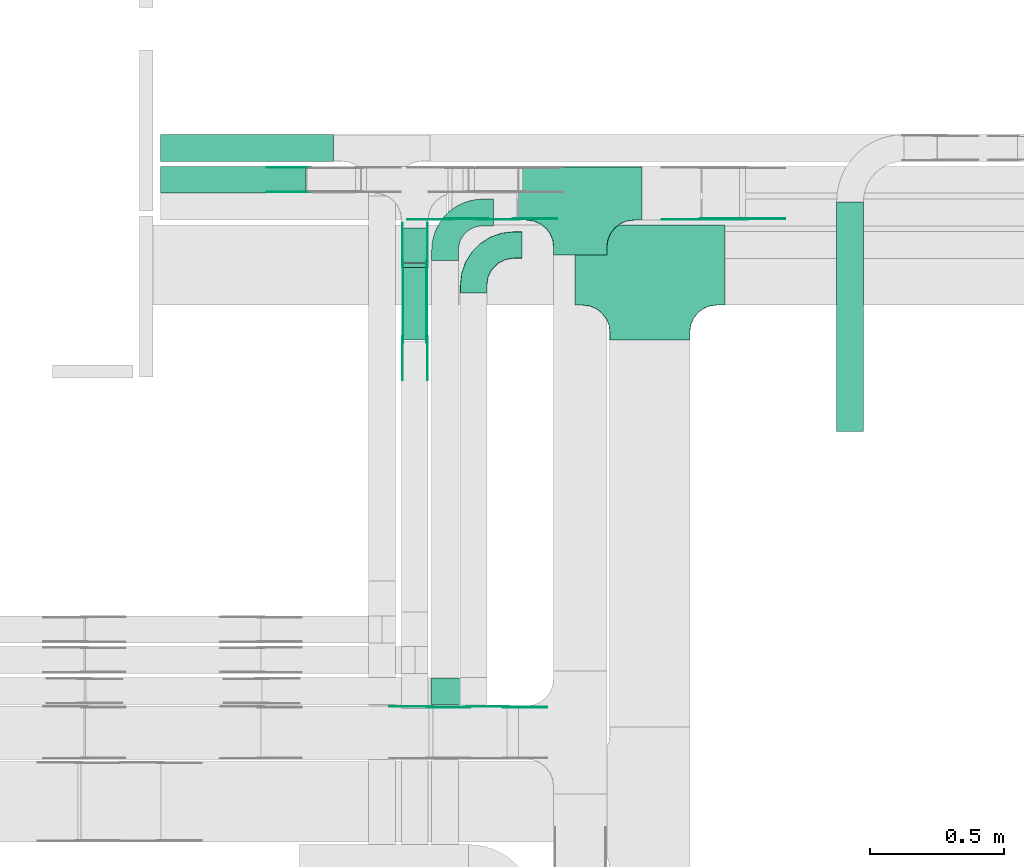
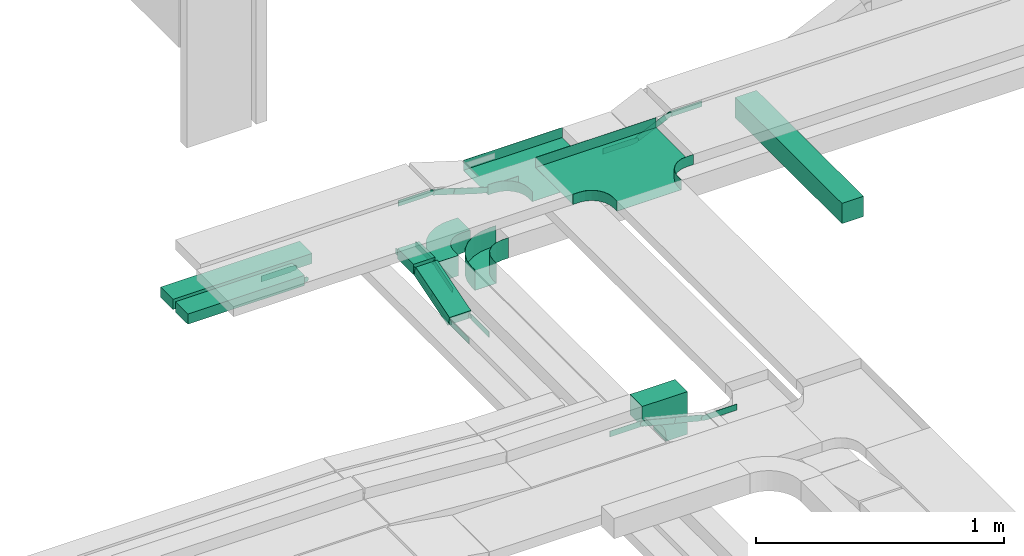
# One storey, part 7 of 19: 27 flow fittings, 5 flow segments.
"""IFC2X3 building model written with IfcOpenShell, lengths in millimetres."""

from ifc_helpers import new_model, entity, si_unit, converted_unit, derived_unit, direction, frame, frame_2d, origin, origin_2d_with_axis, place, context, subcontext, project, spatial, polyline, circle_curve, parameter, trimmed, segment, composite_curve, rectangle, outline, extrude, faceted_brep, source, transform, mapped, material, type_object, type_shapes, element, save


model = new_model("IFC2X3")

# Units and contexts
model_context = context("Model", 3, precision=0.01, world=origin(), true_north=direction((6.12303176911189e-17, 1.0)))
body_context = subcontext(model_context, "Body", "Model", "MODEL_VIEW")
ifc_project = project(units=[si_unit("LENGTHUNIT", "METRE", prefix="MILLI"), si_unit("AREAUNIT", "SQUARE_METRE"), si_unit("VOLUMEUNIT", "CUBIC_METRE"), converted_unit("PLANEANGLEUNIT", "DEGREE", entity("IfcRatioMeasure", 0.0174532925199433), si_unit("PLANEANGLEUNIT", "RADIAN"), dimensions=[0, 0, 0, 0, 0, 0, 0]), si_unit("MASSUNIT", "GRAM", prefix="KILO"), derived_unit("MASSDENSITYUNIT", [(si_unit("MASSUNIT", "GRAM", prefix="KILO"), 1), (si_unit("LENGTHUNIT", "METRE"), -3)]), derived_unit("MOMENTOFINERTIAUNIT", [(si_unit("LENGTHUNIT", "METRE"), 4)]), si_unit("TIMEUNIT", "SECOND"), si_unit("FREQUENCYUNIT", "HERTZ"), si_unit("THERMODYNAMICTEMPERATUREUNIT", "DEGREE_CELSIUS"), derived_unit("THERMALTRANSMITTANCEUNIT", [(si_unit("MASSUNIT", "GRAM", prefix="KILO"), 1), (si_unit("THERMODYNAMICTEMPERATUREUNIT", "KELVIN"), -1), (si_unit("TIMEUNIT", "SECOND"), -3)]), derived_unit("VOLUMETRICFLOWRATEUNIT", [(si_unit("LENGTHUNIT", "METRE"), 3), (si_unit("TIMEUNIT", "SECOND"), -1)]), derived_unit("MASSFLOWRATEUNIT", [(si_unit("MASSUNIT", "GRAM", prefix="KILO"), 1), (si_unit("TIMEUNIT", "SECOND"), -1)]), derived_unit("ROTATIONALFREQUENCYUNIT", [(si_unit("TIMEUNIT", "SECOND"), -1)]), si_unit("ELECTRICCURRENTUNIT", "AMPERE"), si_unit("ELECTRICVOLTAGEUNIT", "VOLT"), si_unit("POWERUNIT", "WATT"), si_unit("FORCEUNIT", "NEWTON", prefix="KILO"), si_unit("ILLUMINANCEUNIT", "LUX"), si_unit("LUMINOUSFLUXUNIT", "LUMEN"), si_unit("LUMINOUSINTENSITYUNIT", "CANDELA"), derived_unit("USERDEFINED", [(si_unit("MASSUNIT", "GRAM", prefix="KILO"), -1), (si_unit("LENGTHUNIT", "METRE"), -2), (si_unit("TIMEUNIT", "SECOND"), 3), (si_unit("LUMINOUSFLUXUNIT", "LUMEN"), 1)]), derived_unit("LINEARVELOCITYUNIT", [(si_unit("LENGTHUNIT", "METRE"), 1), (si_unit("TIMEUNIT", "SECOND"), -1)]), si_unit("PRESSUREUNIT", "PASCAL"), derived_unit("USERDEFINED", [(si_unit("LENGTHUNIT", "METRE"), -2), (si_unit("MASSUNIT", "GRAM", prefix="KILO"), 1), (si_unit("TIMEUNIT", "SECOND"), -2)]), derived_unit("LINEARFORCEUNIT", [(si_unit("MASSUNIT", "GRAM", prefix="KILO"), 1), (si_unit("LENGTHUNIT", "METRE"), 1), (si_unit("TIMEUNIT", "SECOND"), -2), (si_unit("LENGTHUNIT", "METRE"), -1)]), derived_unit("PLANARFORCEUNIT", [(si_unit("MASSUNIT", "GRAM", prefix="KILO"), 1), (si_unit("LENGTHUNIT", "METRE"), 1), (si_unit("TIMEUNIT", "SECOND"), -2), (si_unit("LENGTHUNIT", "METRE"), -2)])], contexts=[model_context])

# Site, building, storey
site_placement = place(None, origin())
site = spatial("IfcSite", under=ifc_project, at=site_placement, CompositionType="ELEMENT")
building_placement = place(site_placement, origin())
building = spatial("IfcBuilding", under=site, at=building_placement, CompositionType="ELEMENT")
storey_placement = place(building_placement, frame((0.0, 0.0, 12000.0)))
storey = spatial("IfcBuildingStorey", under=building, at=storey_placement, CompositionType="ELEMENT", Elevation=12000.0)

# Flow segments
cable_carrier_segment_type = type_object("IfcCableCarrierSegmentType", PredefinedType="CABLETRAYSEGMENT")
flow_segment_1_placement = place(storey_placement, frame((16550.94, 14792.5, 2500.0)))
element("IfcFlowSegment", 1, at=flow_segment_1_placement, inside=storey, type_object=cable_carrier_segment_type, context=body_context, shape_type="SweptSolid", body=[
    extrude(rectangle(XDim=646.818670860271, YDim=99.9999999999989, at=origin_2d_with_axis()), frame((323.41, 50.0, 0.0), z_axis=(0.0, 0.0, 1.0), x_axis=(-1.0, 0.0, 0.0)), (0.0, 0.0, 1.0), 50.0000000000016),
])
flow_segment_2_placement = place(storey_placement, frame((16550.94, 14673.63, 2500.0)))
element("IfcFlowSegment", 2, at=flow_segment_2_placement, inside=storey, type_object=cable_carrier_segment_type, context=body_context, shape_type="SweptSolid", body=[
    extrude(rectangle(XDim=543.455150568502, YDim=99.9999999999989, at=origin_2d_with_axis()), frame((271.73, 50.0, 0.0), z_axis=(0.0, 0.0, 1.0), x_axis=(-1.0, 0.0, 0.0)), (0.0, 0.0, 1.0), 49.9999999999995),
])
flow_segment_3_placement = place(storey_placement, frame((17450.8, 14414.52, 2586.13)))
element("IfcFlowSegment", 3, at=flow_segment_3_placement, inside=storey, type_object=cable_carrier_segment_type, context=body_context, shape_type="SweptSolid", body=[
    extrude(rectangle(XDim=129.10701547123, YDim=99.9999999999989, at=origin_2d_with_axis()), frame((50.0, 64.55, 0.0), z_axis=(0.0, 0.0, 1.0), x_axis=(0.0, -1.0, 0.0)), (0.0, 0.0, 1.0), 50.0000000000016),
])
flow_segment_4_placement = place(storey_placement, frame((19076.52, 13782.5, 2650.0)))
element("IfcFlowSegment", 4, at=flow_segment_4_placement, inside=storey, type_object=cable_carrier_segment_type, context=body_context, shape_type="SweptSolid", body=[
    extrude(rectangle(XDim=859.000000000028, YDim=99.9999999999989, at=origin_2d_with_axis()), frame((50.0, 429.5, 0.0), z_axis=(0.0, 0.0, 1.0), x_axis=(0.0, -1.0, 0.0)), (0.0, 0.0, 1.0), 99.9999999999989),
])
flow_segment_5_placement = place(storey_placement, frame((17450.8, 14125.26, 2502.65)))
element("IfcFlowSegment", 5, at=flow_segment_5_placement, inside=storey, type_object=cable_carrier_segment_type, context=body_context, shape_type="SweptSolid", body=[
    extrude(rectangle(XDim=49.9999999999967, YDim=283.929306322978, at=frame_2d((0.0, 0.0), x_axis=(0.0, 1.0))), frame((0.0, 143.07, 65.41), z_axis=(1.0, 0.0, 0.0), x_axis=(0.0, -0.956304755963122, -0.292371704722454)), (0.0, 0.0, 1.0), 99.9999999999989),
])

# Flow fittings
ifc_material_1 = material()
cable_carrier_fitting_type_1 = type_object("IfcCableCarrierFittingType", PredefinedType="NOTDEFINED", material=ifc_material_1)
shared_shape_1 = source(origin(), body_context, "Body", "Brep", [
    faceted_brep([(-153.41, -224.12, 25.0), (-150.0, -250.0, 25.0), (-150.0, -280.0, 25.0), (-149.2, -280.0, 25.0), (-149.2, -250.0, 25.0), (-152.63, -223.91, 25.0), (-162.7, -199.6, 25.0), (-178.72, -178.72, 25.0), (-199.6, -162.7, 25.0), (-223.91, -152.63, 25.0), (-250.0, -149.2, 25.0), (-280.0, -149.2, 25.0), (-280.0, -150.0, 25.0), (-250.0, -150.0, 25.0), (-224.12, -153.41, 25.0), (-200.0, -163.4, 25.0), (-179.29, -179.29, 25.0), (-163.4, -200.0, 25.0), (280.0, -150.0, 25.0), (280.0, -149.2, 25.0), (250.0, -149.2, 25.0), (223.91, -152.63, 25.0), (199.6, -162.7, 25.0), (178.72, -178.72, 25.0), (162.7, -199.6, 25.0), (152.63, -223.91, 25.0), (149.2, -250.0, 25.0), (149.2, -280.0, 25.0), (150.0, -280.0, 25.0), (150.0, -250.0, 25.0), (153.41, -224.12, 25.0), (163.4, -200.0, 25.0), (179.29, -179.29, 25.0), (200.0, -163.4, 25.0), (224.12, -153.41, 25.0), (250.0, -150.0, 25.0), (280.0, 149.2, 25.0), (280.0, 150.0, 25.0), (-280.0, 150.0, 25.0), (-280.0, 149.2, 25.0), (-280.0, -150.0, -25.0), (-280.0, 150.0, -25.0), (280.0, 150.0, -25.0), (280.0, -150.0, -25.0), (250.0, -150.0, -25.0), (224.12, -153.41, -25.0), (200.0, -163.4, -25.0), (179.29, -179.29, -25.0), (163.4, -200.0, -25.0), (153.41, -224.12, -25.0), (150.0, -250.0, -25.0), (150.0, -280.0, -25.0), (-150.0, -280.0, -25.0), (-150.0, -250.0, -25.0), (-153.41, -224.12, -25.0), (-163.4, -200.0, -25.0), (-179.29, -179.29, -25.0), (-200.0, -163.4, -25.0), (-224.12, -153.41, -25.0), (-250.0, -150.0, -25.0), (-150.0, -250.0, -24.2), (149.2, -280.0, -24.2), (-149.2, -280.0, -24.2), (-149.2, -250.0, -24.2), (-250.0, -149.2, -24.2), (-280.0, -149.2, -24.2), (280.0, -149.2, -24.2), (250.0, -149.2, -24.2), (-280.0, 149.2, -24.2), (-250.0, -150.0, -24.2), (250.0, -150.0, -24.2), (280.0, 149.2, -24.2), (149.2, -250.0, -24.2), (150.0, -250.0, -24.2), (-223.91, -152.63, -24.2), (-199.6, -162.7, -24.2), (-178.72, -178.72, -24.2), (-162.7, -199.6, -24.2), (-152.63, -223.91, -24.2), (152.63, -223.91, -24.2), (162.7, -199.6, -24.2), (178.72, -178.72, -24.2), (199.6, -162.7, -24.2), (223.91, -152.63, -24.2)], [[[0, 1, 2, 3, 4, 5, 6, 7, 8, 9, 10, 11, 12, 13, 14, 15, 16, 17]], [[18, 19, 20, 21, 22, 23, 24, 25, 26, 27, 28, 29, 30, 31, 32, 33, 34, 35]], [[36, 37, 38, 39]], [[40, 41, 42, 43, 44, 45, 46, 47, 48, 49, 50, 51, 52, 53, 54, 55, 56, 57, 58, 59]], [[2, 1, 60, 53, 52]], [[3, 2, 52, 51, 28, 27, 61, 62]], [[4, 3, 62, 63]], [[11, 10, 64, 65]], [[20, 19, 66, 67]], [[39, 38, 41, 40, 12, 11, 65, 68]], [[13, 12, 40, 59, 69]], [[18, 35, 70, 44, 43]], [[19, 18, 43, 42, 37, 36, 71, 66]], [[27, 26, 72, 61]], [[29, 28, 51, 50, 73]], [[38, 37, 42, 41]], [[36, 39, 68, 71]], [[68, 65, 64, 74, 75, 76, 77, 78, 63, 62, 61, 72, 79, 80, 81, 82, 83, 67, 66, 71]], [[14, 13, 69, 59, 58]], [[58, 57, 15, 14]], [[15, 57, 56, 16]], [[0, 17, 55, 54]], [[0, 54, 53, 60, 1]], [[55, 17, 16, 56]], [[5, 4, 63, 78]], [[6, 5, 78, 77]], [[7, 6, 77, 76]], [[8, 7, 76, 75]], [[9, 8, 75, 74]], [[10, 9, 74, 64]], [[21, 20, 67, 83]], [[22, 21, 83, 82]], [[23, 22, 82, 81]], [[81, 80, 24, 23]], [[24, 80, 79, 25]], [[79, 72, 26, 25]], [[30, 29, 73, 50, 49]], [[31, 30, 49, 48]], [[31, 48, 47, 32]], [[33, 32, 47, 46]], [[45, 34, 33, 46]], [[34, 45, 44, 70, 35]]]),
])
type_shapes(cable_carrier_fitting_type_1, [shared_shape_1])
flow_fitting_1_placement = place(storey_placement, frame((18378.54, 14405.0, 2825.0)))
element("IfcFlowFitting", 6, at=flow_fitting_1_placement, inside=storey, type_object=cable_carrier_fitting_type_1, material=ifc_material_1, Name="470_DKC_S5_T", context=body_context, shape_type="MappedRepresentation", body=[
    mapped(shared_shape_1, transform((0.0, 0.0, 0.0), scale=1.0)),
])
cable_carrier_fitting_type_2 = type_object("IfcCableCarrierFittingType", PredefinedType="NOTDEFINED", material=ifc_material_1)
shared_shape_2 = source(origin(), body_context, "Body", "Brep", [
    faceted_brep([(-103.41, -174.12, 25.0), (-100.0, -200.0, 25.0), (-100.0, -230.0, 25.0), (-99.2, -230.0, 25.0), (-99.2, -200.0, 25.0), (-102.63, -173.91, 25.0), (-112.7, -149.6, 25.0), (-128.72, -128.72, 25.0), (-149.6, -112.7, 25.0), (-173.91, -102.63, 25.0), (-200.0, -99.2, 25.0), (-230.0, -99.2, 25.0), (-230.0, -100.0, 25.0), (-200.0, -100.0, 25.0), (-174.12, -103.41, 25.0), (-150.0, -113.4, 25.0), (-129.29, -129.29, 25.0), (-113.4, -150.0, 25.0), (230.0, -100.0, 25.0), (230.0, -99.2, 25.0), (200.0, -99.2, 25.0), (173.91, -102.63, 25.0), (149.6, -112.7, 25.0), (128.72, -128.72, 25.0), (112.7, -149.6, 25.0), (102.63, -173.91, 25.0), (99.2, -200.0, 25.0), (99.2, -230.0, 25.0), (100.0, -230.0, 25.0), (100.0, -200.0, 25.0), (103.41, -174.12, 25.0), (113.4, -150.0, 25.0), (129.29, -129.29, 25.0), (150.0, -113.4, 25.0), (174.12, -103.41, 25.0), (200.0, -100.0, 25.0), (230.0, 99.2, 25.0), (230.0, 100.0, 25.0), (-230.0, 100.0, 25.0), (-230.0, 99.2, 25.0), (-230.0, -100.0, -25.0), (-230.0, 100.0, -25.0), (230.0, 100.0, -25.0), (230.0, -100.0, -25.0), (200.0, -100.0, -25.0), (174.12, -103.41, -25.0), (150.0, -113.4, -25.0), (129.29, -129.29, -25.0), (113.4, -150.0, -25.0), (103.41, -174.12, -25.0), (100.0, -200.0, -25.0), (100.0, -230.0, -25.0), (-100.0, -230.0, -25.0), (-100.0, -200.0, -25.0), (-103.41, -174.12, -25.0), (-113.4, -150.0, -25.0), (-129.29, -129.29, -25.0), (-150.0, -113.4, -25.0), (-174.12, -103.41, -25.0), (-200.0, -100.0, -25.0), (-100.0, -200.0, -24.2), (99.2, -230.0, -24.2), (-99.2, -230.0, -24.2), (-99.2, -200.0, -24.2), (-200.0, -99.2, -24.2), (-230.0, -99.2, -24.2), (230.0, -99.2, -24.2), (200.0, -99.2, -24.2), (-230.0, 99.2, -24.2), (-200.0, -100.0, -24.2), (200.0, -100.0, -24.2), (230.0, 99.2, -24.2), (99.2, -200.0, -24.2), (100.0, -200.0, -24.2), (-173.91, -102.63, -24.2), (-149.6, -112.7, -24.2), (-128.72, -128.72, -24.2), (-112.7, -149.6, -24.2), (-102.63, -173.91, -24.2), (102.63, -173.91, -24.2), (112.7, -149.6, -24.2), (128.72, -128.72, -24.2), (149.6, -112.7, -24.2), (173.91, -102.63, -24.2)], [[[0, 1, 2, 3, 4, 5, 6, 7, 8, 9, 10, 11, 12, 13, 14, 15, 16, 17]], [[18, 19, 20, 21, 22, 23, 24, 25, 26, 27, 28, 29, 30, 31, 32, 33, 34, 35]], [[36, 37, 38, 39]], [[40, 41, 42, 43, 44, 45, 46, 47, 48, 49, 50, 51, 52, 53, 54, 55, 56, 57, 58, 59]], [[2, 1, 60, 53, 52]], [[3, 2, 52, 51, 28, 27, 61, 62]], [[4, 3, 62, 63]], [[11, 10, 64, 65]], [[20, 19, 66, 67]], [[39, 38, 41, 40, 12, 11, 65, 68]], [[13, 12, 40, 59, 69]], [[18, 35, 70, 44, 43]], [[19, 18, 43, 42, 37, 36, 71, 66]], [[27, 26, 72, 61]], [[29, 28, 51, 50, 73]], [[38, 37, 42, 41]], [[36, 39, 68, 71]], [[68, 65, 64, 74, 75, 76, 77, 78, 63, 62, 61, 72, 79, 80, 81, 82, 83, 67, 66, 71]], [[14, 13, 69, 59, 58]], [[58, 57, 15, 14]], [[15, 57, 56, 16]], [[0, 17, 55, 54]], [[0, 54, 53, 60, 1]], [[55, 17, 16, 56]], [[5, 4, 63, 78]], [[6, 5, 78, 77]], [[7, 6, 77, 76]], [[8, 7, 76, 75]], [[9, 8, 75, 74]], [[10, 9, 74, 64]], [[21, 20, 67, 83]], [[22, 21, 83, 82]], [[23, 22, 82, 81]], [[81, 80, 24, 23]], [[24, 80, 79, 25]], [[79, 72, 26, 25]], [[30, 29, 73, 50, 49]], [[31, 30, 49, 48]], [[31, 48, 47, 32]], [[33, 32, 47, 46]], [[45, 34, 33, 46]], [[34, 45, 44, 70, 35]]]),
])
type_shapes(cable_carrier_fitting_type_2, [shared_shape_2])
flow_fitting_2_placement = place(storey_placement, frame((18118.59, 14672.5, 2752.85)))
element("IfcFlowFitting", 7, at=flow_fitting_2_placement, inside=storey, type_object=cable_carrier_fitting_type_2, material=ifc_material_1, Name="470_DKC_S5_T", context=body_context, shape_type="MappedRepresentation", body=[
    mapped(shared_shape_2, transform((0.0, 0.0, 0.0), scale=1.0)),
])
cable_carrier_fitting_type_3 = type_object("IfcCableCarrierFittingType", Name="470_DKC_S5_CPO 45 horizontal angle:-", PredefinedType="NOTDEFINED", material=ifc_material_1)
shared_shape_3 = source(origin(), body_context, "Body", "Brep", [
    faceted_brep([(-180.0, -49.2, -49.2), (-180.0, 49.2, -49.2), (-180.0, 49.2, 50.0), (-180.0, 50.0, 50.0), (-180.0, 50.0, -50.0), (-180.0, -50.0, -50.0), (-180.0, -50.0, 50.0), (-180.0, -49.2, 50.0), (-150.0, -50.0, -50.0), (-150.0, -50.0, 50.0), (-105.5, -44.99, 50.0), (-63.22, -30.19, 50.0), (-25.3, -6.37, 50.0), (6.37, 25.3, 50.0), (30.19, 63.22, 50.0), (44.99, 105.5, 50.0), (50.0, 150.0, 50.0), (50.0, 180.0, 50.0), (49.2, 180.0, 50.0), (49.2, 150.0, 50.0), (44.21, 105.67, 50.0), (29.47, 63.57, 50.0), (5.74, 25.8, 50.0), (-25.8, -5.74, 50.0), (-63.57, -29.47, 50.0), (-105.67, -44.21, 50.0), (-150.0, -49.2, 50.0), (-150.0, 49.2, 50.0), (-118.85, 54.13, 50.0), (-90.75, 68.45, 50.0), (-68.45, 90.75, 50.0), (-54.13, 118.85, 50.0), (-49.2, 150.0, 50.0), (-49.2, 180.0, 50.0), (-50.0, 180.0, 50.0), (-50.0, 150.0, 50.0), (-54.89, 119.1, 50.0), (-69.1, 91.22, 50.0), (-91.22, 69.1, 50.0), (-119.1, 54.89, 50.0), (-150.0, 50.0, 50.0), (-150.0, -49.2, -49.2), (-105.67, -44.21, -49.2), (-63.57, -29.47, -49.2), (-25.8, -5.74, -49.2), (5.74, 25.8, -49.2), (29.47, 63.57, -49.2), (44.21, 105.67, -49.2), (49.2, 150.0, -49.2), (49.2, 180.0, -49.2), (-49.2, 180.0, -49.2), (-49.2, 150.0, -49.2), (-54.13, 118.85, -49.2), (-68.45, 90.75, -49.2), (-90.75, 68.45, -49.2), (-118.85, 54.13, -49.2), (-150.0, 49.2, -49.2), (-150.0, 50.0, -50.0), (-119.1, 54.89, -50.0), (-91.22, 69.1, -50.0), (-69.1, 91.22, -50.0), (-54.89, 119.1, -50.0), (-50.0, 150.0, -50.0), (-50.0, 180.0, -50.0), (50.0, 180.0, -50.0), (50.0, 150.0, -50.0), (44.99, 105.5, -50.0), (30.19, 63.22, -50.0), (6.37, 25.3, -50.0), (-25.3, -6.37, -50.0), (-63.22, -30.19, -50.0), (-105.5, -44.99, -50.0)], [[[0, 1, 2, 3, 4, 5, 6, 7]], [[6, 5, 8, 9]], [[7, 6, 9, 10, 11, 12, 13, 14, 15, 16, 17, 18, 19, 20, 21, 22, 23, 24, 25, 26]], [[3, 2, 27, 28, 29, 30, 31, 32, 33, 34, 35, 36, 37, 38, 39, 40]], [[0, 7, 26, 41]], [[1, 0, 41, 42, 43, 44, 45, 46, 47, 48, 49, 50, 51, 52, 53, 54, 55, 56]], [[2, 1, 56, 27]], [[4, 3, 40, 57]], [[57, 58, 59, 60, 61, 62, 63, 64, 65, 66, 67, 68, 69, 70, 71, 8, 5, 4]], [[10, 9, 8, 71]], [[71, 70, 11, 10]], [[69, 12, 11, 70]], [[69, 68, 13, 12]], [[13, 68, 67, 14]], [[14, 67, 66, 15]], [[15, 66, 65, 16]], [[42, 41, 26, 25]], [[24, 43, 42, 25]], [[43, 24, 23, 44]], [[23, 22, 45, 44]], [[46, 45, 22, 21]], [[47, 46, 21, 20]], [[48, 47, 20, 19]], [[55, 54, 29, 28]], [[56, 55, 28, 27]], [[54, 53, 30, 29]], [[30, 53, 52, 31]], [[31, 52, 51, 32]], [[39, 38, 59, 58]], [[39, 58, 57, 40]], [[38, 37, 60, 59]], [[61, 60, 37, 36]], [[62, 61, 36, 35]], [[63, 34, 33, 50, 49, 18, 17, 64]], [[16, 65, 64, 17]], [[48, 19, 18, 49]], [[32, 51, 50, 33]], [[62, 35, 34, 63]]]),
])
type_shapes(cable_carrier_fitting_type_3, [shared_shape_3])
flow_fitting_3_placement = place(storey_placement, frame((17720.3, 14479.99, 2550.0), z_axis=(-1.54615696088747e-06, 0.0, 1.0), x_axis=(-1.0, 0.0, -1.54615696088747e-06)))
element("IfcFlowFitting", 8, at=flow_fitting_3_placement, inside=storey, type_object=cable_carrier_fitting_type_3, material=ifc_material_1, Name="470_DKC_S5_45 horizontal angle", ObjectType="470_DKC_S5_CPO 45 horizontal angle:-", context=body_context, shape_type="MappedRepresentation", body=[
    mapped(shared_shape_3, transform((0.0, 0.0, 0.0), scale=1.0)),
])
cable_carrier_fitting_type_4 = type_object("IfcCableCarrierFittingType", Name="470_DKC_S5_CDV 90 external vertical angle:-", PredefinedType="NOTDEFINED", material=ifc_material_1)
shared_shape_4 = source(origin(), body_context, "Body", "SweptSolid", [
    extrude(outline(composite_curve([segment(polyline([(65.71, 14.29), (95.71, 14.29)]), True, "CONTINUOUS"), segment(polyline([(95.71, 14.29), (95.71, 114.29)]), True, "CONTINUOUS"), segment(polyline([(95.71, 114.29), (-114.29, 114.29)]), True, "CONTINUOUS"), segment(polyline([(-114.29, 114.29), (-114.29, -95.71)]), True, "CONTINUOUS"), segment(polyline([(-114.29, -95.71), (-14.29, -95.71)]), True, "CONTINUOUS"), segment(polyline([(-14.29, -95.71), (-14.29, -65.71)]), True, "CONTINUOUS"), segment(trimmed(circle_curve(frame_2d((65.71, -65.71), x_axis=(-1.0, 0.0)), 80.0), [parameter(270.0)], [parameter(2.54444374517082e-13)], True, "PARAMETER"), False, "CONTINUOUS")], self_intersect=False)), frame((-64.29, 64.29, -49.0), z_axis=(0.0, 0.0, 1.0), x_axis=(-1.0, 0.0, 0.0)), (0.0, 0.0, 1.0), 99.0000000000002),
])
type_shapes(cable_carrier_fitting_type_4, [shared_shape_4])
flow_fitting_4_placement = place(storey_placement, frame((17720.3, 12814.16, 2850.0), z_axis=(0.0, -1.0, 0.0), x_axis=(0.0, 0.0, 1.0)))
element("IfcFlowFitting", 9, at=flow_fitting_4_placement, inside=storey, type_object=cable_carrier_fitting_type_4, material=ifc_material_1, Name="470_DKC_S5_90 external vertical angle", ObjectType="470_DKC_S5_CDV 90 external vertical angle:-", context=body_context, shape_type="MappedRepresentation", body=[
    mapped(shared_shape_4, transform((0.0, 0.0, 0.0), scale=1.0)),
])
ifc_material_2 = material(Name="G")
cable_carrier_fitting_type_5 = type_object("IfcCableCarrierFittingType", PredefinedType="NOTDEFINED", material=ifc_material_2)
shared_shape_5 = source(origin(), body_context, "Body", "SweptSolid", [
    extrude(outline(composite_curve([segment(trimmed(circle_curve(frame_2d((-44.59, 0.0), x_axis=(1.0, 0.0)), 12.5), [parameter(90.0000000000007)], [parameter(270.0)], True, "PARAMETER"), True, "CONTINUOUS"), segment(polyline([(-44.59, -12.5), (-33.09, -12.5)]), True, "CONTINUOUS"), segment(polyline([(-33.09, -12.5), (-31.23, -14.5)]), True, "CONTINUOUS"), segment(polyline([(-31.23, -14.5), (108.91, -14.5)]), True, "CONTINUOUS"), segment(polyline([(108.91, -14.5), (108.91, 14.5)]), True, "CONTINUOUS"), segment(polyline([(108.91, 14.5), (-31.23, 14.5)]), True, "CONTINUOUS"), segment(polyline([(-31.23, 14.5), (-33.09, 12.5)]), True, "CONTINUOUS"), segment(polyline([(-33.09, 12.5), (-44.59, 12.5)]), True, "CONTINUOUS")], self_intersect=False)), frame((44.59, 0.0, 0.0), z_axis=(0.0, 0.0, -1.0), x_axis=(1.0, 0.0, 0.0)), (0.0, 0.0, -1.0), 2.0),
])
type_shapes(cable_carrier_fitting_type_5, [shared_shape_5])
flow_fitting_5_placement = place(storey_placement, frame((18731.64, 14577.04, 2825.0), z_axis=(0.0, -1.0, 0.0), x_axis=(-0.906307787036605, 0.0, -0.422618261740797)))
element("IfcFlowFitting", 10, at=flow_fitting_5_placement, inside=storey, type_object=cable_carrier_fitting_type_5, material=ifc_material_2, context=body_context, shape_type="MappedRepresentation", body=[
    mapped(shared_shape_5, transform((0.0, 0.0, 0.0), scale=1.0)),
])
cable_carrier_fitting_type_6 = type_object("IfcCableCarrierFittingType", PredefinedType="NOTDEFINED", material=ifc_material_2)
type_shapes(cable_carrier_fitting_type_6, [shared_shape_5])
for number, where, z_axis, x_axis in (
    (11, (18576.92, 14579.04, 2752.85), (0.0, -1.0, 0.0), (0.906307787036631, 0.0, 0.42261826174074)),
    (12, (17879.49, 14579.04, 2752.85), (0.0, -1.0, 0.0), (1.0, 0.0, 0.0)),
):
    element("IfcFlowFitting", number, at=place(storey_placement, frame(where, z_axis=z_axis, x_axis=x_axis)), inside=storey, type_object=cable_carrier_fitting_type_6, material=ifc_material_2, context=body_context, shape_type="MappedRepresentation", body=[
        mapped(shared_shape_5, transform((0.0, 0.0, 0.0), scale=1.0)),
    ])
for number, where, z_axis, x_axis in (
    (13, (17626.27, 14577.04, 2830.27), (0.0, -1.0, 0.0), (-1.0, 0.0, 0.0)),
    (14, (17101.56, 14769.09, 2525.0), (0.0, 1.0, 0.0), (-1.0, 0.0, 0.0)),
    (15, (17455.34, 14409.19, 2611.13), (-1.0, 0.0, 0.0), (0.0, 1.0, 0.0)),
):
    element("IfcFlowFitting", number, at=place(storey_placement, frame(where, z_axis=z_axis, x_axis=x_axis)), inside=storey, type_object=cable_carrier_fitting_type_5, material=ifc_material_2, context=body_context, shape_type="MappedRepresentation", body=[
        mapped(shared_shape_5, transform((0.0, 0.0, 0.0), scale=1.0)),
    ])
flow_fitting_6_placement = place(storey_placement, frame((17544.26, 14409.19, 2611.13), z_axis=(1.0, 0.0, 0.0), x_axis=(0.0, -0.956304755963097, -0.292371704722536)))
element("IfcFlowFitting", 16, at=flow_fitting_6_placement, inside=storey, type_object=cable_carrier_fitting_type_6, material=ifc_material_2, context=body_context, shape_type="MappedRepresentation", body=[
    mapped(shared_shape_5, transform((0.0, 0.0, 0.0), scale=1.0)),
])
flow_fitting_7_placement = place(storey_placement, frame((17455.34, 14127.46, 2525.0), z_axis=(-1.0, 0.0, 0.0), x_axis=(0.0, -1.0, 0.0)))
element("IfcFlowFitting", 17, at=flow_fitting_7_placement, inside=storey, type_object=cable_carrier_fitting_type_5, material=ifc_material_2, context=body_context, shape_type="MappedRepresentation", body=[
    mapped(shared_shape_5, transform((0.0, 0.0, 0.0), scale=1.0)),
])
flow_fitting_8_placement = place(storey_placement, frame((17544.26, 14127.46, 2525.0), z_axis=(1.0, 0.0, 0.0), x_axis=(0.0, 0.956304755963132, 0.292371704722421)))
element("IfcFlowFitting", 18, at=flow_fitting_8_placement, inside=storey, type_object=cable_carrier_fitting_type_6, material=ifc_material_2, context=body_context, shape_type="MappedRepresentation", body=[
    mapped(shared_shape_5, transform((0.0, 0.0, 0.0), scale=1.0)),
])
flow_fitting_9_placement = place(storey_placement, frame((17841.16, 12754.26, 2752.85), z_axis=(0.0, 1.0, 0.0), x_axis=(-0.969084530600981, 0.0, 0.246728945504732)))
element("IfcFlowFitting", 19, at=flow_fitting_9_placement, inside=storey, type_object=cable_carrier_fitting_type_5, material=ifc_material_2, context=body_context, shape_type="MappedRepresentation", body=[
    mapped(shared_shape_5, transform((0.0, 0.0, 0.0), scale=1.0)),
])
flow_fitting_10_placement = place(storey_placement, frame((17557.78, 12752.26, 2825.0), z_axis=(0.0, 1.0, 0.0), x_axis=(0.96908453060098, 0.0, -0.246728945504733)))
element("IfcFlowFitting", 20, at=flow_fitting_10_placement, inside=storey, type_object=cable_carrier_fitting_type_6, material=ifc_material_2, context=body_context, shape_type="MappedRepresentation", body=[
    mapped(shared_shape_5, transform((0.0, 0.0, 0.0), scale=1.0)),
])
cable_carrier_fitting_type_7 = type_object("IfcCableCarrierFittingType", PredefinedType="NOTDEFINED", material=ifc_material_2)
shared_shape_6 = source(origin(), body_context, "Body", "SweptSolid", [
    extrude(outline(composite_curve([segment(trimmed(circle_curve(frame_2d((-44.59, 0.0), x_axis=(1.0, 0.0)), 12.5), [parameter(90.0000000000007)], [parameter(270.0)], True, "PARAMETER"), True, "CONTINUOUS"), segment(polyline([(-44.59, -12.5), (-33.09, -12.5)]), True, "CONTINUOUS"), segment(polyline([(-33.09, -12.5), (-31.23, -14.5)]), True, "CONTINUOUS"), segment(polyline([(-31.23, -14.5), (108.91, -14.5)]), True, "CONTINUOUS"), segment(polyline([(108.91, -14.5), (108.91, 14.5)]), True, "CONTINUOUS"), segment(polyline([(108.91, 14.5), (-31.23, 14.5)]), True, "CONTINUOUS"), segment(polyline([(-31.23, 14.5), (-33.09, 12.5)]), True, "CONTINUOUS"), segment(polyline([(-33.09, 12.5), (-44.59, 12.5)]), True, "CONTINUOUS")], self_intersect=False)), frame((44.59, 0.0, 0.0)), (0.0, 0.0, 1.0), 2.0),
])
type_shapes(cable_carrier_fitting_type_7, [shared_shape_6])
flow_fitting_11_placement = place(storey_placement, frame((18731.64, 14579.04, 2825.0), z_axis=(0.0, -1.0, 0.0), x_axis=(1.0, 0.0, 0.0)))
element("IfcFlowFitting", 21, at=flow_fitting_11_placement, inside=storey, type_object=cable_carrier_fitting_type_7, material=ifc_material_2, context=body_context, shape_type="MappedRepresentation", body=[
    mapped(shared_shape_6, transform((0.0, 0.0, 0.0), scale=1.0)),
])
cable_carrier_fitting_type_8 = type_object("IfcCableCarrierFittingType", PredefinedType="NOTDEFINED", material=ifc_material_2)
type_shapes(cable_carrier_fitting_type_8, [shared_shape_6])
for number, where, z_axis, x_axis in (
    (22, (18576.92, 14577.04, 2752.85), (0.0, -1.0, 0.0), (-1.0, 0.0, 0.0)),
    (23, (17879.49, 14577.04, 2752.85), (0.0, -1.0, 0.0), (-0.956304755962822, 0.0, 0.292371704723434)),
):
    element("IfcFlowFitting", number, at=place(storey_placement, frame(where, z_axis=z_axis, x_axis=x_axis)), inside=storey, type_object=cable_carrier_fitting_type_8, material=ifc_material_2, context=body_context, shape_type="MappedRepresentation", body=[
        mapped(shared_shape_6, transform((0.0, 0.0, 0.0), scale=1.0)),
    ])
flow_fitting_12_placement = place(storey_placement, frame((17626.27, 14579.04, 2830.27), z_axis=(0.0, -1.0, 0.0), x_axis=(0.956304755964475, 0.0, -0.29237170471803)))
element("IfcFlowFitting", 24, at=flow_fitting_12_placement, inside=storey, type_object=cable_carrier_fitting_type_7, material=ifc_material_2, context=body_context, shape_type="MappedRepresentation", body=[
    mapped(shared_shape_6, transform((0.0, 0.0, 0.0), scale=1.0)),
])
for number, where, z_axis, x_axis in (
    (25, (17101.56, 14678.17, 2525.0), (0.0, -1.0, 0.0), (-1.0, 0.0, 0.0)),
    (26, (17546.26, 14409.19, 2611.13), (1.0, 0.0, 0.0), (0.0, 1.0, 0.0)),
):
    element("IfcFlowFitting", number, at=place(storey_placement, frame(where, z_axis=z_axis, x_axis=x_axis)), inside=storey, type_object=cable_carrier_fitting_type_8, material=ifc_material_2, context=body_context, shape_type="MappedRepresentation", body=[
        mapped(shared_shape_6, transform((0.0, 0.0, 0.0), scale=1.0)),
    ])
flow_fitting_13_placement = place(storey_placement, frame((17457.34, 14409.19, 2611.13), z_axis=(-1.0, 0.0, 0.0), x_axis=(0.0, -0.956304755963097, -0.292371704722536)))
element("IfcFlowFitting", 27, at=flow_fitting_13_placement, inside=storey, type_object=cable_carrier_fitting_type_7, material=ifc_material_2, context=body_context, shape_type="MappedRepresentation", body=[
    mapped(shared_shape_6, transform((0.0, 0.0, 0.0), scale=1.0)),
])
flow_fitting_14_placement = place(storey_placement, frame((17546.26, 14127.46, 2525.0), z_axis=(1.0, 0.0, 0.0), x_axis=(0.0, -1.0, 0.0)))
element("IfcFlowFitting", 28, at=flow_fitting_14_placement, inside=storey, type_object=cable_carrier_fitting_type_8, material=ifc_material_2, context=body_context, shape_type="MappedRepresentation", body=[
    mapped(shared_shape_6, transform((0.0, 0.0, 0.0), scale=1.0)),
])
for number, where, z_axis, x_axis in (
    (29, (17457.34, 14127.46, 2525.0), (-1.0, 0.0, 0.0), (0.0, 0.956304755963132, 0.292371704722421)),
    (30, (17841.16, 12752.26, 2752.85), (0.0, 1.0, 0.0), (1.0, 0.0, 0.0)),
):
    element("IfcFlowFitting", number, at=place(storey_placement, frame(where, z_axis=z_axis, x_axis=x_axis)), inside=storey, type_object=cable_carrier_fitting_type_7, material=ifc_material_2, context=body_context, shape_type="MappedRepresentation", body=[
        mapped(shared_shape_6, transform((0.0, 0.0, 0.0), scale=1.0)),
    ])
flow_fitting_15_placement = place(storey_placement, frame((17557.78, 12754.26, 2825.0), z_axis=(0.0, 1.0, 0.0), x_axis=(-1.0, 0.0, 0.0)))
element("IfcFlowFitting", 31, at=flow_fitting_15_placement, inside=storey, type_object=cable_carrier_fitting_type_8, material=ifc_material_2, context=body_context, shape_type="MappedRepresentation", body=[
    mapped(shared_shape_6, transform((0.0, 0.0, 0.0), scale=1.0)),
])
cable_carrier_fitting_type_9 = type_object("IfcCableCarrierFittingType", Name="470_DKC_S5_CD 90 external vertical angle:-", PredefinedType="NOTDEFINED", material=ifc_material_1)
shared_shape_7 = source(origin(), body_context, "Body", "SweptSolid", [
    extrude(outline(composite_curve([segment(polyline([(-100.0, -130.0), (-60.0, -130.0)]), True, "CONTINUOUS"), segment(trimmed(circle_curve(frame_2d((-60.0, 60.0), x_axis=(0.0, -1.0)), 189.999999999999), [parameter(0.0)], [parameter(90.0)], True, "PARAMETER"), True, "CONTINUOUS"), segment(polyline([(130.0, 60.0), (130.0, 100.0)]), True, "CONTINUOUS"), segment(polyline([(130.0, 100.0), (30.0, 100.0)]), True, "CONTINUOUS"), segment(polyline([(30.0, 100.0), (30.0, 60.0)]), True, "CONTINUOUS"), segment(trimmed(circle_curve(frame_2d((-60.0, 60.0), x_axis=(0.0, -1.0)), 89.9999999999988), [parameter(0.0)], [parameter(90.0)], True, "PARAMETER"), False, "CONTINUOUS"), segment(polyline([(-60.0, -30.0), (-100.0, -30.0)]), True, "CONTINUOUS"), segment(polyline([(-100.0, -30.0), (-100.0, -130.0)]), True, "CONTINUOUS")], self_intersect=False)), frame((-80.0, 80.0, -50.0)), (0.0, 0.0, 1.0), 99.9999999999999),
])
type_shapes(cable_carrier_fitting_type_9, [shared_shape_7])
flow_fitting_16_placement = place(storey_placement, frame((17613.86, 14601.42, 2552.04), z_axis=(0.000377553037564522, -0.000472682466877915, 0.999999817012478), x_axis=(-0.999999928726833, 0.0, 0.000377553079742624)))
element("IfcFlowFitting", 32, at=flow_fitting_16_placement, inside=storey, type_object=cable_carrier_fitting_type_9, material=ifc_material_1, Name="470_DKC_S5_CD 90 external vertical angle:-", ObjectType="470_DKC_S5_CD 90 external vertical angle:-", context=body_context, shape_type="MappedRepresentation", body=[
    mapped(shared_shape_7, transform((0.0, 0.0, 0.0), scale=1.0)),
])

save(model, "model.ifc")
